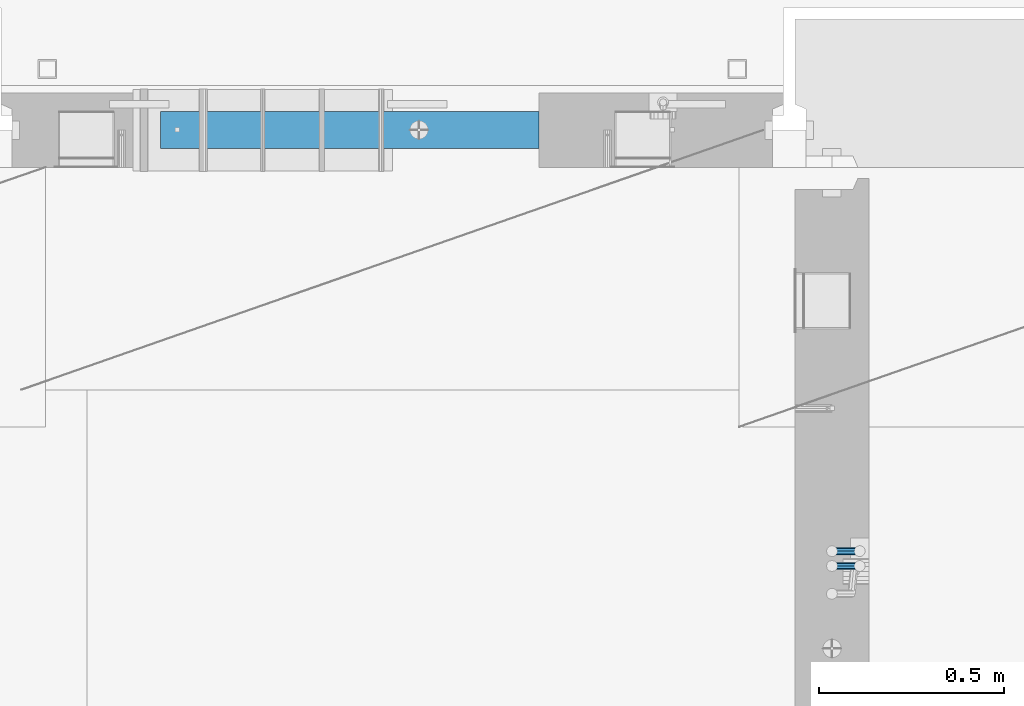
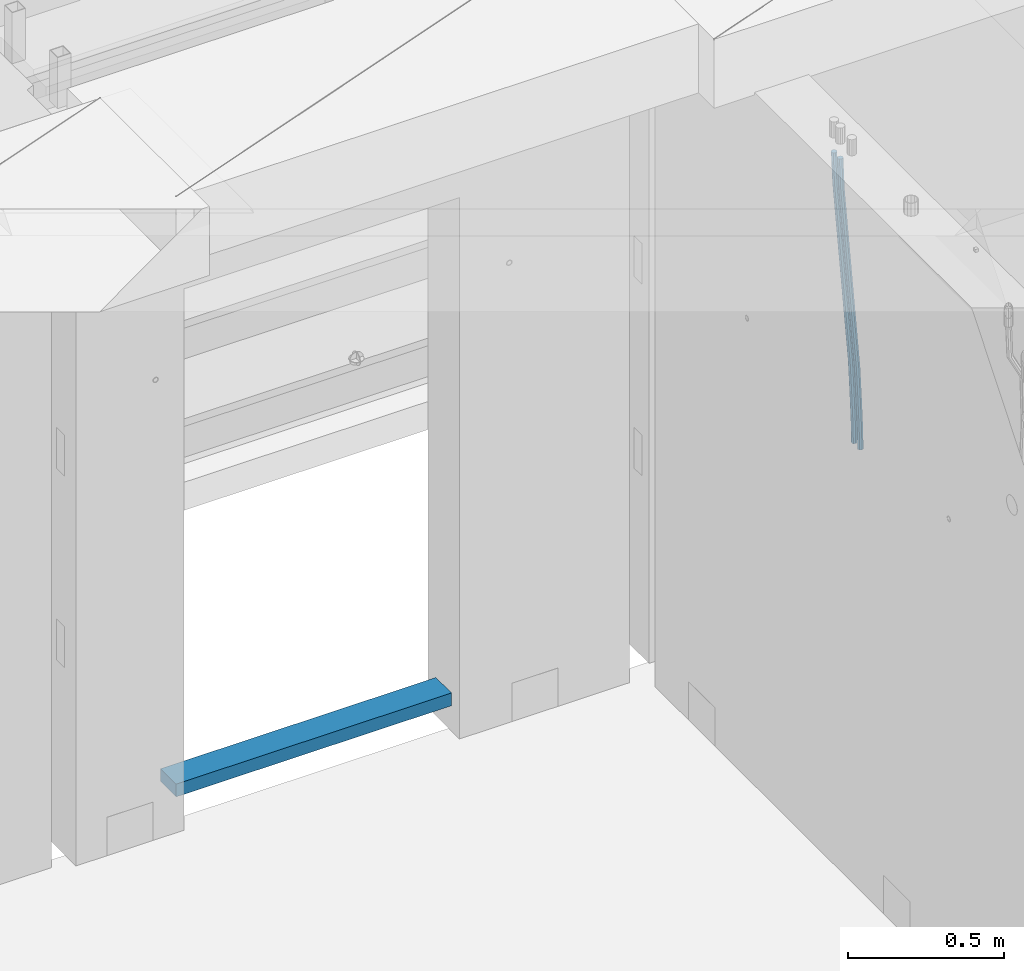
# One storey, part 97 of 325: 3 beams, 2 elements without a shape of their own.
"""IFC2X3 building model written with IfcOpenShell, lengths in millimetres."""

import ifcopenshell
import ifcopenshell.guid

model = None  # the IFC model being written
_history = None  # IfcOwnerHistory: only IFC2X3 demands one
_inside = {}  # id of a spatial element -> (the spatial element, [elements in it])
_under = {}  # id of a project, library or spatial element -> (it, [spatial elements below it])
_declared = {}  # id of a project -> (the project, [libraries it declares])
_typed = {}  # id of a type object -> (the type object, [elements of that type])
_made_of = {}  # id of a material, layer set ... -> (it, [elements and type objects made of it])


def new_model(schema):
    """Start an empty IFC model of exactly this schema.

    Asked for "IFC4X3", IfcOpenShell would pick the latest addendum, in which some entities
    have other attributes; the version numbers below select the first issue.
    IFC2X3 requires an IfcOwnerHistory on every rooted entity: one is made here for all.
    """
    global model, _history
    if schema == "IFC4X3":
        model = ifcopenshell.file(schema_version=(4, 3, 0, 0))
    else:
        model = ifcopenshell.file(schema=schema)
    _inside.clear()
    _under.clear()
    _declared.clear()
    _typed.clear()
    _made_of.clear()
    _history = None
    if model.schema == "IFC2X3":
        org = make("IfcOrganization", Name="unknown")
        user = make(
            "IfcPersonAndOrganization",
            ThePerson=make("IfcPerson", FamilyName="unknown"),
            TheOrganization=org,
        )
        app = make(
            "IfcApplication",
            ApplicationDeveloper=org,
            Version="unknown",
            ApplicationFullName="unknown",
            ApplicationIdentifier="unknown",
        )
        _history = make(
            "IfcOwnerHistory",
            OwningUser=user,
            OwningApplication=app,
            ChangeAction="ADDED",
            CreationDate=0,
        )
    return model


def make(cls, **values):
    """One entity of the class cls with the attributes given. An attribute that is None is left unset."""
    return model.create_entity(
        cls, **{name: value for name, value in values.items() if value is not None}
    )


def rooted(cls, **values):
    """An entity with a GlobalId (a new one), such as an element, a storey or a relation."""
    return make(cls, GlobalId=ifcopenshell.guid.new(), OwnerHistory=_history, **values)


def si_unit(unit_type, name, prefix=None):
    """IfcSIUnit, for example si_unit("LENGTHUNIT", "METRE", prefix="MILLI")."""
    return make("IfcSIUnit", UnitType=unit_type, Prefix=prefix, Name=name)


def assignment(units):
    """IfcUnitAssignment: the units of a project."""
    return None if units is None else make("IfcUnitAssignment", Units=units)


def point(xyz):
    """IfcCartesianPoint."""
    return None if xyz is None else make("IfcCartesianPoint", Coordinates=xyz)


def direction(xyz):
    """IfcDirection."""
    return None if xyz is None else make("IfcDirection", DirectionRatios=xyz)


def frame(location, z_axis=None, x_axis=None):
    """IfcAxis2Placement3D, a coordinate frame: its origin and axes. An axis left out is left unset."""
    return make(
        "IfcAxis2Placement3D",
        Location=point(location),
        Axis=direction(z_axis),
        RefDirection=direction(x_axis),
    )


def origin_with_axes():
    """The frame at (0, 0, 0) with the z axis (0, 0, 1) and the x axis (1, 0, 0) written out."""
    return frame((0.0, 0.0, 0.0), z_axis=(0.0, 0.0, 1.0), x_axis=(1.0, 0.0, 0.0))


def place(relative_to, where):
    """IfcLocalPlacement: puts the frame where relative to a parent placement (None: the world)."""
    return make(
        "IfcLocalPlacement", PlacementRelTo=relative_to, RelativePlacement=where
    )


def context(
    kind, dimensions, precision=None, world=None, true_north=None, identifier=None
):
    """IfcGeometricRepresentationContext, for example the 3D "Model" context."""
    return make(
        "IfcGeometricRepresentationContext",
        ContextIdentifier=identifier,
        ContextType=kind,
        CoordinateSpaceDimension=dimensions,
        Precision=precision,
        WorldCoordinateSystem=world,
        TrueNorth=true_north,
    )


def subcontext(parent, identifier, kind, view, scale=None):
    """IfcGeometricRepresentationSubContext, for example "Body" below "Model"."""
    return make(
        "IfcGeometricRepresentationSubContext",
        ContextIdentifier=identifier,
        ContextType=kind,
        ParentContext=parent,
        TargetScale=scale,
        TargetView=view,
    )


def project(units=None, contexts=None):
    """IfcProject with its units and contexts."""
    return rooted(
        "IfcProject",
        Name="project",
        RepresentationContexts=contexts,
        UnitsInContext=assignment(units),
    )


def spatial(cls, under=None, at=None, **own):
    """A site, building, storey or space (cls), placed at a placement, below another one or the project."""
    s = rooted(cls, ObjectPlacement=at, **own)
    if under is not None:
        _under.setdefault(under.id(), (under, []))[1].append(s)
    return s


def faces_of(points, faces, orient=None, outer=None):
    """IfcFace entities. A face is a list of loops; a loop is a list of indices into points, from 0.

    orient and outer hold one flag for each loop. By default every Orientation is true, the
    first loop of a face is its IfcFaceOuterBound and the others are IfcFaceBound.
    """
    made = []
    for i, loops in enumerate(faces):
        bounds = []
        for j, loop in enumerate(loops):
            is_outer = j == 0 if outer is None else outer[i][j]
            bounds.append(
                make(
                    "IfcFaceOuterBound" if is_outer else "IfcFaceBound",
                    Bound=make("IfcPolyLoop", Polygon=[points[k] for k in loop]),
                    Orientation=True if orient is None else orient[i][j],
                )
            )
        made.append(make("IfcFace", Bounds=bounds))
    return made


def faceted_brep(points, faces, orient=None, outer=None, voids=None):
    """IfcFacetedBrep: a solid bounded by flat faces; with voids (closed shells), ...WithVoids."""
    shared = [point(p) for p in points]
    hull = make("IfcClosedShell", CfsFaces=faces_of(shared, faces, orient, outer))
    if voids is None:
        return make("IfcFacetedBrep", Outer=hull)
    return make(
        "IfcFacetedBrepWithVoids",
        Outer=hull,
        Voids=[
            make(cls, CfsFaces=faces_of(shared, fs, o, b)) for cls, fs, o, b in voids
        ],
    )


def shape(context_of_items, identifier, shape_type, items):
    """IfcShapeRepresentation: the items that make up one representation, for example the "Body"."""
    return make(
        "IfcShapeRepresentation",
        ContextOfItems=context_of_items,
        RepresentationIdentifier=identifier,
        RepresentationType=shape_type,
        Items=items,
    )


def material(Name=None, Category=None):
    """IfcMaterial."""
    return make("IfcMaterial", Name=Name, Category=Category)


def made_of(thing, what):
    """Note that an element or type object is made of a material, layer set ...; save() writes the relation."""
    if what is not None:
        _made_of.setdefault(what.id(), (what, []))[1].append(thing)
    return thing


def type_object(cls, material=None, **own):
    """A type object (cls), such as IfcWallType, which elements share."""
    return made_of(rooted(cls, **own), material)


def element(
    cls,
    number,
    at=None,
    inside=None,
    cuts=None,
    type_object=None,
    material=None,
    context=None,
    identifier="Body",
    shape_type=None,
    held_by="IfcProductDefinitionShape",
    body=None,
    shapes=None,
    **own,
):
    """One element of the class cls, such as IfcWall. Its Tag is "e" and its number.

    at: its placement. inside: the storey or other place that contains it. cuts: it is an
    opening in that element (IfcRelVoidsElement). A single representation is given by context,
    identifier, shape_type and body (its items); several are given by shapes. held_by: the class
    of the entity that holds the representations. save() writes the other relations.
    """
    e = rooted(cls, Tag="e%d" % number, ObjectPlacement=at, **own)
    if body is not None:
        shapes = [shape(context, identifier, shape_type, body)]
    if shapes is not None:
        e.Representation = make(held_by, Representations=shapes)
    if inside is not None:
        _inside.setdefault(inside.id(), (inside, []))[1].append(e)
    if cuts is not None:
        rooted(
            "IfcRelVoidsElement", RelatingBuildingElement=cuts, RelatedOpeningElement=e
        )
    if type_object is not None:
        _typed.setdefault(type_object.id(), (type_object, []))[1].append(e)
    return made_of(e, material)


def aggregate(whole, parts):
    """IfcRelAggregates: a whole, such as a stair, and the parts it consists of."""
    return rooted("IfcRelAggregates", RelatingObject=whole, RelatedObjects=parts)


def save(model, path):
    """Write the relations noted so far, then the file.

    IfcRelAggregates (storeys below a building ...), IfcRelContainedInSpatialStructure (elements
    in a storey), IfcRelDefinesByType, IfcRelAssociatesMaterial and IfcRelDeclares: one each for
    every whole, place, type object, material and project.
    """
    for whole, parts in _under.values():
        aggregate(whole, parts)
    for where, things in _inside.values():
        rooted(
            "IfcRelContainedInSpatialStructure",
            RelatedElements=things,
            RelatingStructure=where,
        )
    for kind, things in _typed.values():
        rooted("IfcRelDefinesByType", RelatedObjects=things, RelatingType=kind)
    for what, things in _made_of.values():
        rooted("IfcRelAssociatesMaterial", RelatedObjects=things, RelatingMaterial=what)
    for by, libraries in _declared.values():
        rooted("IfcRelDeclares", RelatingContext=by, RelatedDefinitions=libraries)
    model.write(path)


model = new_model("IFC2X3")

# Units and contexts
model_context = context("Model", 3, precision=1e-05, world=origin_with_axes())
body_context = subcontext(model_context, "Body", "Model", "MODEL_VIEW")
ifc_project = project(units=[si_unit("LENGTHUNIT", "METRE", prefix="MILLI"), si_unit("AREAUNIT", "SQUARE_METRE"), si_unit("VOLUMEUNIT", "CUBIC_METRE"), si_unit("MASSUNIT", "GRAM", prefix="KILO"), si_unit("TIMEUNIT", "SECOND"), si_unit("PLANEANGLEUNIT", "RADIAN"), si_unit("SOLIDANGLEUNIT", "STERADIAN"), si_unit("THERMODYNAMICTEMPERATUREUNIT", "DEGREE_CELSIUS"), si_unit("LUMINOUSINTENSITYUNIT", "LUMEN")], contexts=[model_context])

# Site, building, storey
site_placement = place(None, origin_with_axes())
site = spatial("IfcSite", under=ifc_project, at=site_placement, CompositionType="ELEMENT")
building_placement = place(site_placement, origin_with_axes())
building = spatial("IfcBuilding", under=site, at=building_placement, CompositionType="ELEMENT")
storey_placement = place(building_placement, origin_with_axes())
storey = spatial("IfcBuildingStorey", under=building, at=storey_placement, Name="1", CompositionType="ELEMENT", Elevation=0.0)

# Assembly, beams
assembly_1_placement = place(storey_placement, origin_with_axes())
assembly_1 = element("IfcElementAssembly", 1, at=assembly_1_placement, inside=storey, AssemblyPlace="NOTDEFINED", PredefinedType="REINFORCEMENT_UNIT")
ifc_material_1 = material()
beam_type_1 = type_object("IfcBeamType", Name="D20", PredefinedType="NOTDEFINED")
beam_1_placement = place(assembly_1_placement, frame((21885.0000022791, 14045.0000000039, 83242.5), z_axis=(-0.999820284539475, -0.000205762999905157, -0.0189566949912691), x_axis=(-0.0189566949945633, 3.09999984783362e-08, 0.999820305712423)))
beam_1 = element("IfcBeam", 2, at=beam_1_placement, type_object=beam_type_1, material=ifc_material_1, Name="JM20", ObjectType="D20", context=body_context, shape_type="Brep", body=[
    faceted_brep([(0.0, -10.0, 0.0), (-4.19531716033816e-08, -7.07106781186667, -7.07106781187031), (85.3814813058561, -7.07106783855306, -7.07106781027323), (85.3814813076606, -10.0000000266882, 1.58615875989199e-09), (0.0, 0.0, -10.0), (85.381481306933, -2.66882125288248e-08, -9.9999999984102), (4.196772351861e-08, 7.07106781186303, -7.07106781186667), (85.3814813102799, 7.07106778517664, -7.07106781027687), (0.0, 10.0, 0.0), (85.3814813139179, 9.99999997331361, 1.58979673869908e-09), (4.196772351861e-08, 7.07106781185939, 7.07106781185939), (85.3814813157223, 7.07106778517664, 7.07106781345647), (0.0, 0.0, 10.0), (85.3814813146601, -2.66863935394213e-08, 10.0000000015898), (-4.19531716033816e-08, -7.07106781187031, 7.07106781185939), (85.3814813113131, -7.07106783855306, 7.07106781345647), (86.0589861600893, -7.07106783876588, -7.07106781025868), (85.9854738744616, -10.0000000268774, 1.60071067512035e-09), (86.0894233170693, -2.69101292360574e-08, -9.99999999839565), (86.0589556716441, 7.07106778496563, -7.07106781026232), (85.9854307572532, 9.99999997312261, 1.60434865392745e-09), (85.9119184716255, 7.07106778501111, 7.07106781346374), (85.8814813146455, -2.68446456175298e-08, 10.0000000016007), (85.9119489600853, -7.07106783871859, 7.07106781346374), (86.7363445540104, -7.07106491765808, -7.05698116088388), (86.5893358725152, -9.99999742272485, 0.0125581869215239), (86.7972122870997, 3.02542866847944e-06, -9.98528050109235), (86.7362835792737, 7.07107070594066, -7.05698179489264), (86.5892496412271, 10.0000025770914, 0.0125572902979911), (86.4422409597319, 7.07107007202831, 7.08209663810703), (86.3813732266281, 2.12893792195246e-06, 10.0103959783119), (86.4423019344686, -7.07106555157225, 7.08209727211579), (201.576579767396, -7.07056966943492, -4.66871205216376), (201.429571085901, -9.99950217449987, 2.40082729564529), (201.637447500485, 0.00049827365182864, -7.59701139237222), (201.576518792659, 7.07156595416382, -4.66871268616887), (201.429484854598, 10.0004978253128, 2.40082639902175), (201.282476173117, 7.07156532024783, 9.47036574682716), (201.221608440013, 0.000497377159263124, 12.3986650870356), (201.282537147839, -7.07057030335091, 9.47036638083955), (202.132124882439, -7.07056727364943, -4.65715868644475), (201.96206784925, -9.99949987810942, 2.41190133749114), (202.202535595599, 0.000500710591950337, -7.58525956654921), (202.132054347894, 7.07156834990747, -4.65715951926177), (201.961968098345, 10.0005001216468, 2.41190015971006), (201.791911065156, 7.07156751718503, 9.48096018364595), (201.721500351996, 0.000499532941830694, 12.4090610637504), (201.791981599716, -7.07056810637368, 9.48096101645933), (202.687582846644, -7.07056412668317, -4.64198287962427), (202.494481077447, -9.99949686170658, 2.42644753327841), (202.767535042804, 0.000503911614941899, -7.5698230744747), (202.68750275379, 7.07157149682098, -4.64198397358632), (202.494367809079, 10.0005031379733, 2.42644598618062), (202.301266039882, 7.07157040295351, 9.4948763990833), (202.221313843707, 0.000502364651765674, 12.4227165939337), (202.301346132735, -7.07056522055063, 9.49487749304899), (324.450236720237, -7.06987427631248, -1.31527477285636), (324.257134951054, -9.99880701133588, 5.75315564004995), (324.530188916411, 0.00119376198563259, -4.24311496770679), (324.450156627383, 7.07226134718985, -1.31527586681841), (324.257021682657, 10.001192988344, 5.75315409294853), (324.063919913475, 7.07226025332238, 12.8215845058512), (323.9839677173, 0.00119221502245637, 15.7494247007053), (324.064000006329, -7.06987537017994, 12.8215855998169), (325.241843259806, -7.06986979143949, -1.2936470913919), (324.927897486399, -9.99880321110686, 5.771481712065), (325.37183004785, 0.00119853033174877, -4.22012027856181), (325.241713353011, 7.07226583178272, -1.29364954632547), (324.927713770478, 10.0011967881728, 5.77147824025451), (324.613767997056, 7.07226336850545, 12.8366070437114), (324.483781209012, 0.00119504673421034, 15.7630802308813), (324.613897903837, -7.06987225471858, 12.8366094986523), (326.032247754891, -7.06985973207702, -1.24497056535256), (325.597641477347, -9.99879468737527, 5.81272744259331), (326.212193157917, 0.00120922550922842, -4.16836708502888), (326.032068109809, 7.07227589051217, -1.24497608339516), (325.597387420843, 10.0012053110113, 5.81271963891049), (325.162781143299, 7.07227035571668, 12.8704176468491), (324.982835740273, 0.00120139812679554, 15.7938141665254), (325.162960788366, -7.06986526687615, 12.8704231648881), (1042.36854212308, -7.06074302482739, 42.8701154434457), (1041.93393584553, -9.98967798012382, 49.9278134513916), (1042.54848752609, 0.0103259327588603, 39.946718923773), (1042.36836247802, 7.08139259775999, 42.8701099254067), (1041.93368178904, 10.0103220182609, 49.9278056477051), (1041.4990755115, 7.0813870629645, 56.9855036556546), (1041.31913010847, 0.0103181053782464, 59.9089001753237), (1041.49925515657, -7.06074855962288, 56.9855091736936), (1042.88062679839, -7.060736507603, 42.9016518316894), (1042.56961579039, -9.98966988991924, 49.9669613706901), (1043.04754205736, 0.0103322841532645, 39.9774528594171), (1042.97258487239, 7.08140028761227, 42.9073205527457), (1042.69966414581, 10.0103317668072, 49.9749781528772), (1042.38865313782, 7.08139838448915, 57.0402876918706), (1042.22173787885, 0.0103295927347062, 59.9644866641502), (1042.29669506381, -7.06073841072066, 57.0346189708253), (1043.39352406697, -7.06742486028452, 42.9124646169512), (1043.20630445368, -9.9979725239773, 49.9803838983862), (1043.54738850522, 0.00381411855232727, 39.9879905101952), (1043.57776606729, 7.07350852152376, 42.9200788470553), (1043.46686198929, 10.0003272491958, 49.9911520458591), (1043.279642376, 7.06977958550488, 57.0590713272904), (1043.12577793775, -0.00145939333560818, 59.9835454340428), (1043.09540037568, -7.07115379630523, 57.05145709719), (1065.09494198511, -7.35041864031518, 43.3699690454596), (1064.90772237183, -10.2809663040043, 50.437888326891), (1065.24880642339, -0.279179661472881, 40.4454949387073), (1065.27918398545, 6.79051474149492, 43.3775832755564), (1065.16827990745, 9.71733346916517, 50.4486564743675), (1064.98106029416, 6.78678580547603, 57.5165757557988), (1064.82719585591, -0.284453173368092, 60.4410498625548), (1064.79681829385, -7.35414757633407, 57.5089615256948), (1065.73027839647, -7.35870364055336, 43.3833630652807), (1065.56772267689, -10.2895729297052, 50.451802305397), (1065.82701873672, -0.286719744282891, 40.457684681096), (1065.80127451834, 6.78370650555371, 43.3885898711524), (1065.6681263553, 9.71081530356605, 50.4591941251456), (1065.50557063572, 6.77994601441787, 57.5276333652582), (1065.40883029549, -0.292037881850774, 60.4533117494429), (1065.43457451386, -7.36246413169283, 57.5224065593902), (1066.36567012158, -7.35682702138729, 43.3965627352663), (1066.22778023187, -10.2876033214088, 50.465521669892), (1066.40528178558, -0.285021624051296, 40.4696799052072), (1066.32341124835, 6.78524517929691, 43.3994014460841), (1066.16801716023, 9.7123069848567, 50.4695362132297), (1066.03012727054, 6.78153068483152, 57.5384951478518), (1065.99051560652, -0.290274712500832, 60.4653779779183), (1066.07238614376, -7.36054151585085, 57.5356564370377), (1166.3733554564, -7.05840377136155, 45.4710776546162), (1166.23546556669, -9.98918007138673, 52.5400365892456), (1166.41296712038, 0.0134016259744385, 42.5441948245534), (1166.33109658316, 7.08366842932264, 45.473916365434), (1166.17570249505, 10.0107302348806, 52.5440511325796), (1166.03781260535, 7.07995393485544, 59.6130100672053), (1165.99820094134, 0.00814853752308409, 62.5398928972681), (1166.08007147857, -7.06211826582876, 59.6101713563876)], [[[0, 1, 2, 3]], [[1, 4, 5, 2]], [[4, 6, 7, 5]], [[6, 8, 9, 7]], [[8, 10, 11, 9]], [[10, 12, 13, 11]], [[12, 14, 15, 13]], [[14, 0, 3, 15]], [[14, 12, 10, 8, 6, 4, 1, 0]], [[3, 2, 16, 17]], [[2, 5, 18, 16]], [[5, 7, 19, 18]], [[7, 9, 20, 19]], [[9, 11, 21, 20]], [[11, 13, 22, 21]], [[13, 15, 23, 22]], [[15, 3, 17, 23]], [[17, 16, 24, 25]], [[16, 18, 26, 24]], [[18, 19, 27, 26]], [[19, 20, 28, 27]], [[20, 21, 29, 28]], [[21, 22, 30, 29]], [[22, 23, 31, 30]], [[23, 17, 25, 31]], [[25, 24, 32, 33]], [[24, 26, 34, 32]], [[26, 27, 35, 34]], [[27, 28, 36, 35]], [[28, 29, 37, 36]], [[29, 30, 38, 37]], [[30, 31, 39, 38]], [[31, 25, 33, 39]], [[33, 32, 40, 41]], [[32, 34, 42, 40]], [[34, 35, 43, 42]], [[35, 36, 44, 43]], [[36, 37, 45, 44]], [[37, 38, 46, 45]], [[38, 39, 47, 46]], [[39, 33, 41, 47]], [[41, 40, 48, 49]], [[40, 42, 50, 48]], [[42, 43, 51, 50]], [[43, 44, 52, 51]], [[44, 45, 53, 52]], [[45, 46, 54, 53]], [[46, 47, 55, 54]], [[47, 41, 49, 55]], [[49, 48, 56, 57]], [[48, 50, 58, 56]], [[50, 51, 59, 58]], [[51, 52, 60, 59]], [[52, 53, 61, 60]], [[53, 54, 62, 61]], [[54, 55, 63, 62]], [[55, 49, 57, 63]], [[57, 56, 64, 65]], [[56, 58, 66, 64]], [[58, 59, 67, 66]], [[59, 60, 68, 67]], [[60, 61, 69, 68]], [[61, 62, 70, 69]], [[62, 63, 71, 70]], [[63, 57, 65, 71]], [[65, 64, 72, 73]], [[64, 66, 74, 72]], [[66, 67, 75, 74]], [[67, 68, 76, 75]], [[68, 69, 77, 76]], [[69, 70, 78, 77]], [[70, 71, 79, 78]], [[71, 65, 73, 79]], [[73, 72, 80, 81]], [[72, 74, 82, 80]], [[74, 75, 83, 82]], [[75, 76, 84, 83]], [[76, 77, 85, 84]], [[77, 78, 86, 85]], [[78, 79, 87, 86]], [[79, 73, 81, 87]], [[81, 80, 88, 89]], [[80, 82, 90, 88]], [[82, 83, 91, 90]], [[83, 84, 92, 91]], [[84, 85, 93, 92]], [[85, 86, 94, 93]], [[86, 87, 95, 94]], [[87, 81, 89, 95]], [[89, 88, 96, 97]], [[88, 90, 98, 96]], [[90, 91, 99, 98]], [[91, 92, 100, 99]], [[92, 93, 101, 100]], [[93, 94, 102, 101]], [[94, 95, 103, 102]], [[95, 89, 97, 103]], [[97, 96, 104, 105]], [[96, 98, 106, 104]], [[98, 99, 107, 106]], [[99, 100, 108, 107]], [[100, 101, 109, 108]], [[101, 102, 110, 109]], [[102, 103, 111, 110]], [[103, 97, 105, 111]], [[105, 104, 112, 113]], [[104, 106, 114, 112]], [[106, 107, 115, 114]], [[107, 108, 116, 115]], [[108, 109, 117, 116]], [[109, 110, 118, 117]], [[110, 111, 119, 118]], [[111, 105, 113, 119]], [[113, 112, 120, 121]], [[112, 114, 122, 120]], [[114, 115, 123, 122]], [[115, 116, 124, 123]], [[116, 117, 125, 124]], [[117, 118, 126, 125]], [[118, 119, 127, 126]], [[119, 113, 121, 127]], [[121, 120, 128, 129]], [[120, 122, 130, 128]], [[122, 123, 131, 130]], [[123, 124, 132, 131]], [[124, 125, 133, 132]], [[125, 126, 134, 133]], [[126, 127, 135, 134]], [[127, 121, 129, 135]], [[130, 131, 132, 133, 134, 135, 129, 128]]]),
])
beam_2_placement = place(assembly_1_placement, frame((21885.0000022791, 14005.0000000039, 83242.5), z_axis=(-0.999820284539475, -0.000205762999905157, -0.0189566949912691), x_axis=(-0.0189566949945633, 3.09999984783362e-08, 0.999820305712423)))
beam_2 = element("IfcBeam", 3, at=beam_2_placement, type_object=beam_type_1, material=ifc_material_1, Name="JM20", ObjectType="D20", context=body_context, shape_type="Brep", body=[
    faceted_brep([(0.0, -10.0, 0.0), (-4.19531716033816e-08, -7.07106781186667, -7.07106781187031), (85.3814813058561, -7.07106783855306, -7.07106781027323), (85.3814813076606, -10.0000000266882, 1.58615875989199e-09), (0.0, 0.0, -10.0), (85.381481306933, -2.66882125288248e-08, -9.9999999984102), (4.196772351861e-08, 7.07106781186303, -7.07106781186667), (85.3814813102799, 7.07106778517664, -7.07106781027687), (0.0, 10.0, 0.0), (85.3814813139179, 9.99999997331361, 1.58979673869908e-09), (4.196772351861e-08, 7.07106781185939, 7.07106781185939), (85.3814813157223, 7.07106778517664, 7.07106781345647), (0.0, 0.0, 10.0), (85.3814813146601, -2.66863935394213e-08, 10.0000000015898), (-4.19531716033816e-08, -7.07106781187031, 7.07106781185939), (85.3814813113131, -7.07106783855306, 7.07106781345647), (86.0589861600893, -7.07106783876588, -7.07106781025868), (85.9854738744616, -10.0000000268774, 1.60071067512035e-09), (86.0894233170693, -2.69101292360574e-08, -9.99999999839565), (86.0589556716441, 7.07106778496563, -7.07106781026232), (85.9854307572532, 9.99999997312261, 1.60434865392745e-09), (85.9119184716255, 7.07106778501111, 7.07106781346374), (85.8814813146455, -2.68446456175298e-08, 10.0000000016007), (85.9119489600853, -7.07106783871859, 7.07106781346374), (86.7363445540104, -7.07106491765808, -7.05698116088388), (86.5893358725152, -9.99999742272485, 0.0125581869215239), (86.7972122870997, 3.02542866847944e-06, -9.98528050109235), (86.7362835792737, 7.07107070594066, -7.05698179489264), (86.5892496412271, 10.0000025770914, 0.0125572902979911), (86.4422409597319, 7.07107007202831, 7.08209663810703), (86.3813732266281, 2.12893792195246e-06, 10.0103959783119), (86.4423019344686, -7.07106555157225, 7.08209727211579), (201.576579767396, -7.07056966943492, -4.66871205216376), (201.429571085901, -9.99950217449987, 2.40082729564529), (201.637447500485, 0.00049827365182864, -7.59701139237222), (201.576518792659, 7.07156595416382, -4.66871268616887), (201.429484854598, 10.0004978253128, 2.40082639902175), (201.282476173117, 7.07156532024783, 9.47036574682716), (201.221608440013, 0.000497377159263124, 12.3986650870356), (201.282537147839, -7.07057030335091, 9.47036638083955), (202.132124882439, -7.07056727364943, -4.65715868644475), (201.96206784925, -9.99949987810942, 2.41190133749114), (202.202535595599, 0.000500710591950337, -7.58525956654921), (202.132054347894, 7.07156834990747, -4.65715951926177), (201.961968098345, 10.0005001216468, 2.41190015971006), (201.791911065156, 7.07156751718503, 9.48096018364595), (201.721500351996, 0.000499532941830694, 12.4090610637504), (201.791981599716, -7.07056810637368, 9.48096101645933), (202.687582846644, -7.07056412668317, -4.64198287962427), (202.494481077447, -9.99949686170658, 2.42644753327841), (202.767535042804, 0.000503911614941899, -7.5698230744747), (202.68750275379, 7.07157149682098, -4.64198397358632), (202.494367809079, 10.0005031379733, 2.42644598618062), (202.301266039882, 7.07157040295351, 9.4948763990833), (202.221313843707, 0.000502364651765674, 12.4227165939337), (202.301346132735, -7.07056522055063, 9.49487749304899), (324.450236720237, -7.06987427631248, -1.31527477285636), (324.257134951054, -9.99880701133588, 5.75315564004995), (324.530188916411, 0.00119376198563259, -4.24311496770679), (324.450156627383, 7.07226134718985, -1.31527586681841), (324.257021682657, 10.001192988344, 5.75315409294853), (324.063919913475, 7.07226025332238, 12.8215845058512), (323.9839677173, 0.00119221502245637, 15.7494247007053), (324.064000006329, -7.06987537017994, 12.8215855998169), (325.241843259806, -7.06986979143949, -1.2936470913919), (324.927897486399, -9.99880321110686, 5.771481712065), (325.37183004785, 0.00119853033174877, -4.22012027856181), (325.241713353011, 7.07226583178272, -1.29364954632547), (324.927713770478, 10.0011967881728, 5.77147824025451), (324.613767997056, 7.07226336850545, 12.8366070437114), (324.483781209012, 0.00119504673421034, 15.7630802308813), (324.613897903837, -7.06987225471858, 12.8366094986523), (326.032247754891, -7.06985973207702, -1.24497056535256), (325.597641477347, -9.99879468737527, 5.81272744259331), (326.212193157917, 0.00120922550922842, -4.16836708502888), (326.032068109809, 7.07227589051217, -1.24497608339516), (325.597387420843, 10.0012053110113, 5.81271963891049), (325.162781143299, 7.07227035571668, 12.8704176468491), (324.982835740273, 0.00120139812679554, 15.7938141665254), (325.162960788366, -7.06986526687615, 12.8704231648881), (1042.36854212308, -7.06074302482739, 42.8701154434457), (1041.93393584553, -9.98967798012382, 49.9278134513916), (1042.54848752609, 0.0103259327588603, 39.946718923773), (1042.36836247802, 7.08139259775999, 42.8701099254067), (1041.93368178904, 10.0103220182609, 49.9278056477051), (1041.4990755115, 7.0813870629645, 56.9855036556546), (1041.31913010847, 0.0103181053782464, 59.9089001753237), (1041.49925515657, -7.06074855962288, 56.9855091736936), (1042.88062679839, -7.060736507603, 42.9016518316894), (1042.56961579039, -9.98966988991924, 49.9669613706901), (1043.04754205736, 0.0103322841532645, 39.9774528594171), (1042.97258487239, 7.08140028761227, 42.9073205527457), (1042.69966414581, 10.0103317668072, 49.9749781528772), (1042.38865313782, 7.08139838448915, 57.0402876918706), (1042.22173787885, 0.0103295927347062, 59.9644866641502), (1042.29669506381, -7.06073841072066, 57.0346189708253), (1043.39352406697, -7.06742486028452, 42.9124646169512), (1043.20630445368, -9.9979725239773, 49.9803838983862), (1043.54738850522, 0.00381411855232727, 39.9879905101952), (1043.57776606729, 7.07350852152376, 42.9200788470553), (1043.46686198929, 10.0003272491958, 49.9911520458591), (1043.279642376, 7.06977958550488, 57.0590713272904), (1043.12577793775, -0.00145939333560818, 59.9835454340428), (1043.09540037568, -7.07115379630523, 57.05145709719), (1065.09494198511, -7.35041864031518, 43.3699690454596), (1064.90772237183, -10.2809663040043, 50.437888326891), (1065.24880642339, -0.279179661472881, 40.4454949387073), (1065.27918398545, 6.79051474149492, 43.3775832755564), (1065.16827990745, 9.71733346916517, 50.4486564743675), (1064.98106029416, 6.78678580547603, 57.5165757557988), (1064.82719585591, -0.284453173368092, 60.4410498625548), (1064.79681829385, -7.35414757633407, 57.5089615256948), (1065.73027839647, -7.35870364055336, 43.3833630652807), (1065.56772267689, -10.2895729297052, 50.451802305397), (1065.82701873672, -0.286719744282891, 40.457684681096), (1065.80127451834, 6.78370650555371, 43.3885898711524), (1065.6681263553, 9.71081530356605, 50.4591941251456), (1065.50557063572, 6.77994601441787, 57.5276333652582), (1065.40883029549, -0.292037881850774, 60.4533117494429), (1065.43457451386, -7.36246413169283, 57.5224065593902), (1066.36567012158, -7.35682702138729, 43.3965627352663), (1066.22778023187, -10.2876033214088, 50.465521669892), (1066.40528178558, -0.285021624051296, 40.4696799052072), (1066.32341124835, 6.78524517929691, 43.3994014460841), (1066.16801716023, 9.7123069848567, 50.4695362132297), (1066.03012727054, 6.78153068483152, 57.5384951478518), (1065.99051560652, -0.290274712500832, 60.4653779779183), (1066.07238614376, -7.36054151585085, 57.5356564370377), (1166.3733554564, -7.05840377136155, 45.4710776546162), (1166.23546556669, -9.98918007138673, 52.5400365892456), (1166.41296712038, 0.0134016259744385, 42.5441948245534), (1166.33109658316, 7.08366842932264, 45.473916365434), (1166.17570249505, 10.0107302348806, 52.5440511325796), (1166.03781260535, 7.07995393485544, 59.6130100672053), (1165.99820094134, 0.00814853752308409, 62.5398928972681), (1166.08007147857, -7.06211826582876, 59.6101713563876)], [[[0, 1, 2, 3]], [[1, 4, 5, 2]], [[4, 6, 7, 5]], [[6, 8, 9, 7]], [[8, 10, 11, 9]], [[10, 12, 13, 11]], [[12, 14, 15, 13]], [[14, 0, 3, 15]], [[14, 12, 10, 8, 6, 4, 1, 0]], [[3, 2, 16, 17]], [[2, 5, 18, 16]], [[5, 7, 19, 18]], [[7, 9, 20, 19]], [[9, 11, 21, 20]], [[11, 13, 22, 21]], [[13, 15, 23, 22]], [[15, 3, 17, 23]], [[17, 16, 24, 25]], [[16, 18, 26, 24]], [[18, 19, 27, 26]], [[19, 20, 28, 27]], [[20, 21, 29, 28]], [[21, 22, 30, 29]], [[22, 23, 31, 30]], [[23, 17, 25, 31]], [[25, 24, 32, 33]], [[24, 26, 34, 32]], [[26, 27, 35, 34]], [[27, 28, 36, 35]], [[28, 29, 37, 36]], [[29, 30, 38, 37]], [[30, 31, 39, 38]], [[31, 25, 33, 39]], [[33, 32, 40, 41]], [[32, 34, 42, 40]], [[34, 35, 43, 42]], [[35, 36, 44, 43]], [[36, 37, 45, 44]], [[37, 38, 46, 45]], [[38, 39, 47, 46]], [[39, 33, 41, 47]], [[41, 40, 48, 49]], [[40, 42, 50, 48]], [[42, 43, 51, 50]], [[43, 44, 52, 51]], [[44, 45, 53, 52]], [[45, 46, 54, 53]], [[46, 47, 55, 54]], [[47, 41, 49, 55]], [[49, 48, 56, 57]], [[48, 50, 58, 56]], [[50, 51, 59, 58]], [[51, 52, 60, 59]], [[52, 53, 61, 60]], [[53, 54, 62, 61]], [[54, 55, 63, 62]], [[55, 49, 57, 63]], [[57, 56, 64, 65]], [[56, 58, 66, 64]], [[58, 59, 67, 66]], [[59, 60, 68, 67]], [[60, 61, 69, 68]], [[61, 62, 70, 69]], [[62, 63, 71, 70]], [[63, 57, 65, 71]], [[65, 64, 72, 73]], [[64, 66, 74, 72]], [[66, 67, 75, 74]], [[67, 68, 76, 75]], [[68, 69, 77, 76]], [[69, 70, 78, 77]], [[70, 71, 79, 78]], [[71, 65, 73, 79]], [[73, 72, 80, 81]], [[72, 74, 82, 80]], [[74, 75, 83, 82]], [[75, 76, 84, 83]], [[76, 77, 85, 84]], [[77, 78, 86, 85]], [[78, 79, 87, 86]], [[79, 73, 81, 87]], [[81, 80, 88, 89]], [[80, 82, 90, 88]], [[82, 83, 91, 90]], [[83, 84, 92, 91]], [[84, 85, 93, 92]], [[85, 86, 94, 93]], [[86, 87, 95, 94]], [[87, 81, 89, 95]], [[89, 88, 96, 97]], [[88, 90, 98, 96]], [[90, 91, 99, 98]], [[91, 92, 100, 99]], [[92, 93, 101, 100]], [[93, 94, 102, 101]], [[94, 95, 103, 102]], [[95, 89, 97, 103]], [[97, 96, 104, 105]], [[96, 98, 106, 104]], [[98, 99, 107, 106]], [[99, 100, 108, 107]], [[100, 101, 109, 108]], [[101, 102, 110, 109]], [[102, 103, 111, 110]], [[103, 97, 105, 111]], [[105, 104, 112, 113]], [[104, 106, 114, 112]], [[106, 107, 115, 114]], [[107, 108, 116, 115]], [[108, 109, 117, 116]], [[109, 110, 118, 117]], [[110, 111, 119, 118]], [[111, 105, 113, 119]], [[113, 112, 120, 121]], [[112, 114, 122, 120]], [[114, 115, 123, 122]], [[115, 116, 124, 123]], [[116, 117, 125, 124]], [[117, 118, 126, 125]], [[118, 119, 127, 126]], [[119, 113, 121, 127]], [[121, 120, 128, 129]], [[120, 122, 130, 128]], [[122, 123, 131, 130]], [[123, 124, 132, 131]], [[124, 125, 133, 132]], [[125, 126, 134, 133]], [[126, 127, 135, 134]], [[127, 121, 129, 135]], [[130, 131, 132, 133, 134, 135, 129, 128]]]),
])
aggregate(assembly_1, [beam_1, beam_2])

# Assembly, beam
assembly_2_placement = place(storey_placement, origin_with_axes())
assembly_2 = element("IfcElementAssembly", 4, at=assembly_2_placement, inside=storey, AssemblyPlace="NOTDEFINED", PredefinedType="REINFORCEMENT_UNIT")
ifc_material_2 = material(Name="TIMBER/T24")
beam_type_2 = type_object("IfcBeamType", PredefinedType="NOTDEFINED")
beam_3_placement = place(assembly_2_placement, frame((20000.0006866455, 15180.0, 81880.0), z_axis=(0.0, 0.0, 1.0), x_axis=(1.0, 0.0, 0.0)))
beam_3 = element("IfcBeam", 5, at=beam_3_placement, type_object=beam_type_2, material=ifc_material_2, context=body_context, shape_type="Brep", body=[
    faceted_brep([(0.0, 50.0, -25.0), (0.0, 50.0, 25.0), (1020.0, 50.0, 25.0), (1020.0, 50.0, -25.0), (0.0, -50.0, 25.0), (1020.0, -50.0, 25.0), (0.0, -50.0, -25.0), (1020.0, -50.0, -25.0)], [[[0, 1, 2, 3]], [[1, 4, 5, 2]], [[4, 6, 7, 5]], [[6, 0, 3, 7]], [[5, 7, 3, 2]], [[6, 4, 1, 0]]]),
])
aggregate(assembly_2, [beam_3])

save(model, "model.ifc")
